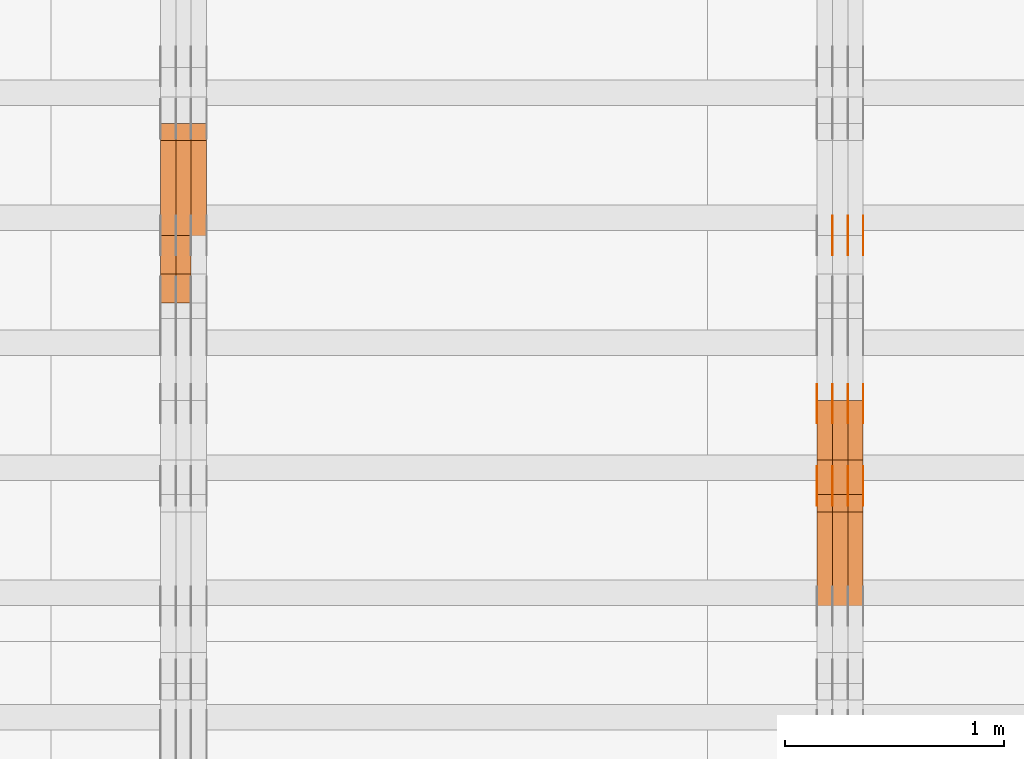
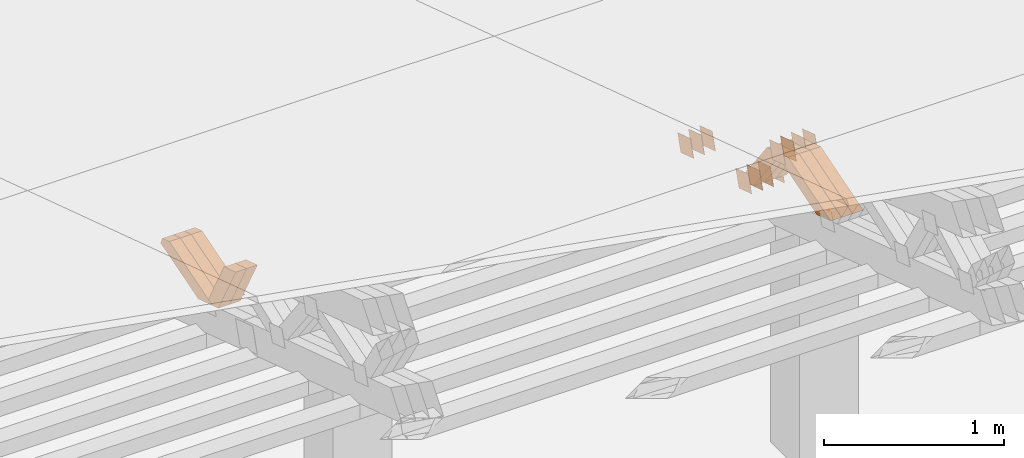
# One storey, part 199 of 385: 28 proxies.
"""IFC2X3 building model written with IfcOpenShell, lengths in millimetres."""

from ifc_helpers import new_model, entity, si_unit, converted_unit, derived_unit, direction, frame, origin, place, context, subcontext, project, spatial, polyline, outline, extrude, source, transform, mapped, material, type_object, type_shapes, element, save


model = new_model("IFC2X3")

# Units and contexts
model_context = context("Model", 3, precision=0.01, world=origin(), true_north=direction((6.12303176911189e-17, 1.0)))
body_context = subcontext(model_context, "Body", "Model", "MODEL_VIEW")
ifc_project = project(units=[si_unit("LENGTHUNIT", "METRE", prefix="MILLI"), si_unit("AREAUNIT", "SQUARE_METRE"), si_unit("VOLUMEUNIT", "CUBIC_METRE"), converted_unit("PLANEANGLEUNIT", "DEGREE", entity("IfcRatioMeasure", 0.0174532925199433), si_unit("PLANEANGLEUNIT", "RADIAN"), dimensions=[0, 0, 0, 0, 0, 0, 0]), si_unit("MASSUNIT", "GRAM", prefix="KILO"), derived_unit("MASSDENSITYUNIT", [(si_unit("MASSUNIT", "GRAM", prefix="KILO"), 1), (si_unit("LENGTHUNIT", "METRE"), -3)]), si_unit("TIMEUNIT", "SECOND"), si_unit("FREQUENCYUNIT", "HERTZ"), si_unit("THERMODYNAMICTEMPERATUREUNIT", "DEGREE_CELSIUS"), derived_unit("THERMALTRANSMITTANCEUNIT", [(si_unit("MASSUNIT", "GRAM", prefix="KILO"), 1), (si_unit("THERMODYNAMICTEMPERATUREUNIT", "KELVIN"), -1), (si_unit("TIMEUNIT", "SECOND"), -3)]), derived_unit("VOLUMETRICFLOWRATEUNIT", [(si_unit("LENGTHUNIT", "METRE"), 3), (si_unit("TIMEUNIT", "SECOND"), -1)]), si_unit("ELECTRICCURRENTUNIT", "AMPERE"), si_unit("ELECTRICVOLTAGEUNIT", "VOLT"), si_unit("POWERUNIT", "WATT"), si_unit("FORCEUNIT", "NEWTON", prefix="KILO"), si_unit("ILLUMINANCEUNIT", "LUX"), si_unit("LUMINOUSFLUXUNIT", "LUMEN"), si_unit("LUMINOUSINTENSITYUNIT", "CANDELA"), derived_unit("USERDEFINED", [(si_unit("MASSUNIT", "GRAM", prefix="KILO"), -1), (si_unit("LENGTHUNIT", "METRE"), -2), (si_unit("TIMEUNIT", "SECOND"), 3), (si_unit("LUMINOUSFLUXUNIT", "LUMEN"), 1)]), derived_unit("LINEARVELOCITYUNIT", [(si_unit("LENGTHUNIT", "METRE"), 1), (si_unit("TIMEUNIT", "SECOND"), -1)]), si_unit("PRESSUREUNIT", "PASCAL"), derived_unit("USERDEFINED", [(si_unit("LENGTHUNIT", "METRE"), -2), (si_unit("MASSUNIT", "GRAM", prefix="KILO"), 1), (si_unit("TIMEUNIT", "SECOND"), -2)])], contexts=[model_context])

# Site, building, storey
site_placement = place(None, origin())
site = spatial("IfcSite", under=ifc_project, at=site_placement, CompositionType="ELEMENT")
building_placement = place(site_placement, origin())
building = spatial("IfcBuilding", under=site, at=building_placement, CompositionType="ELEMENT")
storey_placement = place(building_placement, origin())
storey = spatial("IfcBuildingStorey", under=building, at=storey_placement, Name="Default", CompositionType="ELEMENT", Elevation=0.0)

# Proxies
ifc_material_1 = material(Name="IfcSurfaceStyle #206404")
building_element_proxy_type_1 = type_object("IfcBuildingElementProxyType", PredefinedType="NOTDEFINED", material=ifc_material_1)
shared_shape_1 = source(origin(), body_context, "Body", "SweptSolid", [
    extrude(outline(polyline([(-74.9998794200123, -59.999984515643), (74.9998565677174, -59.999984515643), (74.9998794200123, 59.999984515643), (-74.9998565677174, 59.999984515643), (-74.9998794200123, -59.999984515643)])), frame((75.0000769557496, 60.0000596852268, 0.0), z_axis=(0.0, 0.0, 1.0), x_axis=(-1.0, 0.0, 0.0)), (0.0, 0.0, 1.0), 1.3),
])
type_shapes(building_element_proxy_type_1, [shared_shape_1])
proxy_1_placement = place(building_placement, frame((15386.3, 22649.3668870864, 1282.62115477841), z_axis=(-1.0, 0.0, 0.0), x_axis=(0.0, -0.951056516295124, 0.309016994375039)))
element("IfcBuildingElementProxy", 1, at=proxy_1_placement, inside=storey, type_object=building_element_proxy_type_1, material=ifc_material_1, context=body_context, shape_type="MappedRepresentation", body=[
    mapped(shared_shape_1, transform((0.0, 0.0, 0.0), scale=1.0)),
])
ifc_material_2 = material(Name="IfcSurfaceStyle #206347")
building_element_proxy_type_2 = type_object("IfcBuildingElementProxyType", PredefinedType="NOTDEFINED", material=ifc_material_2)
shared_shape_2 = source(origin(), body_context, "Body", "SweptSolid", [
    extrude(outline(polyline([(-74.9998794200123, -59.999984515643), (74.9998565677174, -59.999984515643), (74.9998794200123, 59.999984515643), (-74.9998565677174, 59.999984515643), (-74.9998794200123, -59.999984515643)])), frame((75.0000769557496, 60.0000596852268, 0.0), z_axis=(0.0, 0.0, 1.0), x_axis=(-1.0, 0.0, 0.0)), (0.0, 0.0, 1.0), 1.3),
])
type_shapes(building_element_proxy_type_2, [shared_shape_2])
proxy_2_placement = place(building_placement, frame((15315.0, 22649.3668870864, 1282.62115477841), z_axis=(-1.0, 0.0, 0.0), x_axis=(0.0, -0.951056516295124, 0.309016994375039)))
element("IfcBuildingElementProxy", 2, at=proxy_2_placement, inside=storey, type_object=building_element_proxy_type_2, material=ifc_material_2, context=body_context, shape_type="MappedRepresentation", body=[
    mapped(shared_shape_2, transform((0.0, 0.0, 0.0), scale=1.0)),
])
ifc_material_3 = material(Name="IfcSurfaceStyle #206290")
building_element_proxy_type_3 = type_object("IfcBuildingElementProxyType", PredefinedType="NOTDEFINED", material=ifc_material_3)
shared_shape_3 = source(origin(), body_context, "Body", "SweptSolid", [
    extrude(outline(polyline([(-74.9998794200123, -59.999984515643), (74.9998565677174, -59.999984515643), (74.9998794200123, 59.999984515643), (-74.9998565677174, 59.999984515643), (-74.9998794200123, -59.999984515643)])), frame((75.0000769557496, 60.0000596852268, 0.0), z_axis=(0.0, 0.0, 1.0), x_axis=(-1.0, 0.0, 0.0)), (0.0, 0.0, 1.0), 1.3),
])
type_shapes(building_element_proxy_type_3, [shared_shape_3])
proxy_3_placement = place(building_placement, frame((15316.3, 22649.3668870864, 1282.62115477841), z_axis=(-1.0, 0.0, 0.0), x_axis=(0.0, -0.951056516295124, 0.309016994375039)))
element("IfcBuildingElementProxy", 3, at=proxy_3_placement, inside=storey, type_object=building_element_proxy_type_3, material=ifc_material_3, context=body_context, shape_type="MappedRepresentation", body=[
    mapped(shared_shape_3, transform((0.0, 0.0, 0.0), scale=1.0)),
])
ifc_material_4 = material(Name="IfcSurfaceStyle #206233")
building_element_proxy_type_4 = type_object("IfcBuildingElementProxyType", PredefinedType="NOTDEFINED", material=ifc_material_4)
shared_shape_4 = source(origin(), body_context, "Body", "SweptSolid", [
    extrude(outline(polyline([(-74.9998794200123, -59.999984515643), (74.9998565677174, -59.999984515643), (74.9998794200123, 59.999984515643), (-74.9998565677174, 59.999984515643), (-74.9998794200123, -59.999984515643)])), frame((75.0000769557496, 60.0000596852268, 0.0), z_axis=(0.0, 0.0, 1.0), x_axis=(-1.0, 0.0, 0.0)), (0.0, 0.0, 1.0), 1.29999999999999),
])
type_shapes(building_element_proxy_type_4, [shared_shape_4])
proxy_4_placement = place(building_placement, frame((15245.0, 22649.3668870864, 1282.62115477841), z_axis=(-1.0, 0.0, 0.0), x_axis=(0.0, -0.951056516295124, 0.309016994375039)))
element("IfcBuildingElementProxy", 4, at=proxy_4_placement, inside=storey, type_object=building_element_proxy_type_4, material=ifc_material_4, context=body_context, shape_type="MappedRepresentation", body=[
    mapped(shared_shape_4, transform((0.0, 0.0, 0.0), scale=1.0)),
])
ifc_material_5 = material(Name="IfcSurfaceStyle #206176")
building_element_proxy_type_5 = type_object("IfcBuildingElementProxyType", PredefinedType="NOTDEFINED", material=ifc_material_5)
shared_shape_5 = source(origin(), body_context, "Body", "SweptSolid", [
    extrude(outline(polyline([(-74.9998794200123, -59.999984515643), (74.9998565677174, -59.999984515643), (74.9998794200123, 59.999984515643), (-74.9998565677174, 59.999984515643), (-74.9998794200123, -59.999984515643)])), frame((75.0000769557496, 60.0000596852268, 0.0), z_axis=(0.0, 0.0, 1.0), x_axis=(-1.0, 0.0, 0.0)), (0.0, 0.0, 1.0), 1.29999999999999),
])
type_shapes(building_element_proxy_type_5, [shared_shape_5])
proxy_5_placement = place(building_placement, frame((15246.3, 22649.3668870864, 1282.62115477841), z_axis=(-1.0, 0.0, 0.0), x_axis=(0.0, -0.951056516295124, 0.309016994375039)))
element("IfcBuildingElementProxy", 5, at=proxy_5_placement, inside=storey, type_object=building_element_proxy_type_5, material=ifc_material_5, context=body_context, shape_type="MappedRepresentation", body=[
    mapped(shared_shape_5, transform((0.0, 0.0, 0.0), scale=1.0)),
])
ifc_material_6 = material(Name="IfcSurfaceStyle #203326")
building_element_proxy_type_6 = type_object("IfcBuildingElementProxyType", PredefinedType="NOTDEFINED", material=ifc_material_6)
shared_shape_6 = source(origin(), body_context, "Body", "SweptSolid", [
    extrude(outline(polyline([(-75.0001116115454, -60.0000599592451), (75.0000887592496, -60.0000599592451), (75.0001116115454, 60.0000599592451), (-75.0000887592496, 60.0000599592451), (-75.0001116115454, -60.0000599592451)])), frame((75.0001116115454, 60.0000599592451, 0.0), z_axis=(0.0, 0.0, 1.0), x_axis=(-1.0, 0.0, 0.0)), (0.0, 0.0, 1.0), 1.3),
])
type_shapes(building_element_proxy_type_6, [shared_shape_6])
proxy_6_placement = place(building_placement, frame((15386.3, 21881.0815195707, 1532.2522473242), z_axis=(-1.0, 0.0, 0.0), x_axis=(0.0, -0.951056516295124, 0.309016994375039)))
element("IfcBuildingElementProxy", 6, at=proxy_6_placement, inside=storey, type_object=building_element_proxy_type_6, material=ifc_material_6, context=body_context, shape_type="MappedRepresentation", body=[
    mapped(shared_shape_6, transform((0.0, 0.0, 0.0), scale=1.0)),
])
ifc_material_7 = material(Name="IfcSurfaceStyle #203269")
building_element_proxy_type_7 = type_object("IfcBuildingElementProxyType", PredefinedType="NOTDEFINED", material=ifc_material_7)
shared_shape_7 = source(origin(), body_context, "Body", "SweptSolid", [
    extrude(outline(polyline([(-75.0001116115454, -60.0000599592451), (75.0000887592496, -60.0000599592451), (75.0001116115454, 60.0000599592451), (-75.0000887592496, 60.0000599592451), (-75.0001116115454, -60.0000599592451)])), frame((75.0001116115454, 60.0000599592451, 0.0), z_axis=(0.0, 0.0, 1.0), x_axis=(-1.0, 0.0, 0.0)), (0.0, 0.0, 1.0), 1.3),
])
type_shapes(building_element_proxy_type_7, [shared_shape_7])
proxy_7_placement = place(building_placement, frame((15315.0, 21881.0815195707, 1532.2522473242), z_axis=(-1.0, 0.0, 0.0), x_axis=(0.0, -0.951056516295124, 0.309016994375039)))
element("IfcBuildingElementProxy", 7, at=proxy_7_placement, inside=storey, type_object=building_element_proxy_type_7, material=ifc_material_7, context=body_context, shape_type="MappedRepresentation", body=[
    mapped(shared_shape_7, transform((0.0, 0.0, 0.0), scale=1.0)),
])
ifc_material_8 = material(Name="IfcSurfaceStyle #203212")
building_element_proxy_type_8 = type_object("IfcBuildingElementProxyType", PredefinedType="NOTDEFINED", material=ifc_material_8)
shared_shape_8 = source(origin(), body_context, "Body", "SweptSolid", [
    extrude(outline(polyline([(-75.0001116115454, -60.0000599592451), (75.0000887592496, -60.0000599592451), (75.0001116115454, 60.0000599592451), (-75.0000887592496, 60.0000599592451), (-75.0001116115454, -60.0000599592451)])), frame((75.0001116115454, 60.0000599592451, 0.0), z_axis=(0.0, 0.0, 1.0), x_axis=(-1.0, 0.0, 0.0)), (0.0, 0.0, 1.0), 1.3),
])
type_shapes(building_element_proxy_type_8, [shared_shape_8])
proxy_8_placement = place(building_placement, frame((15316.3, 21881.0815195707, 1532.2522473242), z_axis=(-1.0, 0.0, 0.0), x_axis=(0.0, -0.951056516295124, 0.309016994375039)))
element("IfcBuildingElementProxy", 8, at=proxy_8_placement, inside=storey, type_object=building_element_proxy_type_8, material=ifc_material_8, context=body_context, shape_type="MappedRepresentation", body=[
    mapped(shared_shape_8, transform((0.0, 0.0, 0.0), scale=1.0)),
])
ifc_material_9 = material(Name="IfcSurfaceStyle #203155")
building_element_proxy_type_9 = type_object("IfcBuildingElementProxyType", PredefinedType="NOTDEFINED", material=ifc_material_9)
shared_shape_9 = source(origin(), body_context, "Body", "SweptSolid", [
    extrude(outline(polyline([(-75.0001116115454, -60.0000599592451), (75.0000887592496, -60.0000599592451), (75.0001116115454, 60.0000599592451), (-75.0000887592496, 60.0000599592451), (-75.0001116115454, -60.0000599592451)])), frame((75.0001116115454, 60.0000599592451, 0.0), z_axis=(0.0, 0.0, 1.0), x_axis=(-1.0, 0.0, 0.0)), (0.0, 0.0, 1.0), 1.29999999999999),
])
type_shapes(building_element_proxy_type_9, [shared_shape_9])
proxy_9_placement = place(building_placement, frame((15245.0, 21881.0815195707, 1532.2522473242), z_axis=(-1.0, 0.0, 0.0), x_axis=(0.0, -0.951056516295124, 0.309016994375039)))
element("IfcBuildingElementProxy", 9, at=proxy_9_placement, inside=storey, type_object=building_element_proxy_type_9, material=ifc_material_9, context=body_context, shape_type="MappedRepresentation", body=[
    mapped(shared_shape_9, transform((0.0, 0.0, 0.0), scale=1.0)),
])
ifc_material_10 = material(Name="IfcSurfaceStyle #203098")
building_element_proxy_type_10 = type_object("IfcBuildingElementProxyType", PredefinedType="NOTDEFINED", material=ifc_material_10)
shared_shape_10 = source(origin(), body_context, "Body", "SweptSolid", [
    extrude(outline(polyline([(-75.0001116115454, -60.0000599592451), (75.0000887592496, -60.0000599592451), (75.0001116115454, 60.0000599592451), (-75.0000887592496, 60.0000599592451), (-75.0001116115454, -60.0000599592451)])), frame((75.0001116115454, 60.0000599592451, 0.0), z_axis=(0.0, 0.0, 1.0), x_axis=(-1.0, 0.0, 0.0)), (0.0, 0.0, 1.0), 1.29999999999999),
])
type_shapes(building_element_proxy_type_10, [shared_shape_10])
proxy_10_placement = place(building_placement, frame((15246.3, 21881.0815195707, 1532.2522473242), z_axis=(-1.0, 0.0, 0.0), x_axis=(0.0, -0.951056516295124, 0.309016994375039)))
element("IfcBuildingElementProxy", 10, at=proxy_10_placement, inside=storey, type_object=building_element_proxy_type_10, material=ifc_material_10, context=body_context, shape_type="MappedRepresentation", body=[
    mapped(shared_shape_10, transform((0.0, 0.0, 0.0), scale=1.0)),
])
ifc_material_11 = material(Name="IfcSurfaceStyle #203041")
building_element_proxy_type_11 = type_object("IfcBuildingElementProxyType", PredefinedType="NOTDEFINED", material=ifc_material_11)
shared_shape_11 = source(origin(), body_context, "Body", "SweptSolid", [
    extrude(outline(polyline([(-75.0001116115454, -60.0000599592451), (75.0000887592496, -60.0000599592451), (75.0001116115454, 60.0000599592451), (-75.0000887592496, 60.0000599592451), (-75.0001116115454, -60.0000599592451)])), frame((75.0001116115454, 60.0000599592451, 0.0), z_axis=(0.0, 0.0, 1.0), x_axis=(-1.0, 0.0, 0.0)), (0.0, 0.0, 1.0), 1.29999999999999),
])
type_shapes(building_element_proxy_type_11, [shared_shape_11])
proxy_11_placement = place(building_placement, frame((15175.0, 21881.0815195707, 1532.2522473242), z_axis=(-1.0, 0.0, 0.0), x_axis=(0.0, -0.951056516295124, 0.309016994375039)))
element("IfcBuildingElementProxy", 11, at=proxy_11_placement, inside=storey, type_object=building_element_proxy_type_11, material=ifc_material_11, context=body_context, shape_type="MappedRepresentation", body=[
    mapped(shared_shape_11, transform((0.0, 0.0, 0.0), scale=1.0)),
])
ifc_material_12 = material(Name="IfcSurfaceStyle #197854")
building_element_proxy_type_12 = type_object("IfcBuildingElementProxyType", PredefinedType="NOTDEFINED", material=ifc_material_12)
shared_shape_12 = source(origin(), body_context, "Body", "SweptSolid", [
    extrude(outline(polyline([(-74.9998794200064, -59.9999845156358), (74.9998565677224, -59.9999845156358), (74.9998794200064, 59.9999845156358), (-74.9998565677224, 59.9999845156358), (-74.9998794200064, -59.9999845156358)])), frame((74.9999765995044, 60.0000596852337, 0.0), z_axis=(0.0, 0.0, 1.0), x_axis=(-1.0, 0.0, 0.0)), (0.0, 0.0, 1.0), 1.3),
])
type_shapes(building_element_proxy_type_12, [shared_shape_12])
proxy_12_placement = place(building_placement, frame((15386.3, 21505.9776314857, 1954.5332951652), z_axis=(-1.0, 0.0, 0.0), x_axis=(0.0, -0.951056516295154, 0.309016994374948)))
element("IfcBuildingElementProxy", 12, at=proxy_12_placement, inside=storey, type_object=building_element_proxy_type_12, material=ifc_material_12, context=body_context, shape_type="MappedRepresentation", body=[
    mapped(shared_shape_12, transform((0.0, 0.0, 0.0), scale=1.0)),
])
ifc_material_13 = material(Name="IfcSurfaceStyle #197797")
building_element_proxy_type_13 = type_object("IfcBuildingElementProxyType", PredefinedType="NOTDEFINED", material=ifc_material_13)
shared_shape_13 = source(origin(), body_context, "Body", "SweptSolid", [
    extrude(outline(polyline([(-74.9998794200064, -59.9999845156358), (74.9998565677224, -59.9999845156358), (74.9998794200064, 59.9999845156358), (-74.9998565677224, 59.9999845156358), (-74.9998794200064, -59.9999845156358)])), frame((74.9999765995044, 60.0000596852337, 0.0), z_axis=(0.0, 0.0, 1.0), x_axis=(-1.0, 0.0, 0.0)), (0.0, 0.0, 1.0), 1.3),
])
type_shapes(building_element_proxy_type_13, [shared_shape_13])
proxy_13_placement = place(building_placement, frame((15315.0, 21505.9776314857, 1954.5332951652), z_axis=(-1.0, 0.0, 0.0), x_axis=(0.0, -0.951056516295154, 0.309016994374948)))
element("IfcBuildingElementProxy", 13, at=proxy_13_placement, inside=storey, type_object=building_element_proxy_type_13, material=ifc_material_13, context=body_context, shape_type="MappedRepresentation", body=[
    mapped(shared_shape_13, transform((0.0, 0.0, 0.0), scale=1.0)),
])
ifc_material_14 = material(Name="IfcSurfaceStyle #197740")
building_element_proxy_type_14 = type_object("IfcBuildingElementProxyType", PredefinedType="NOTDEFINED", material=ifc_material_14)
shared_shape_14 = source(origin(), body_context, "Body", "SweptSolid", [
    extrude(outline(polyline([(-74.9998794200064, -59.9999845156358), (74.9998565677224, -59.9999845156358), (74.9998794200064, 59.9999845156358), (-74.9998565677224, 59.9999845156358), (-74.9998794200064, -59.9999845156358)])), frame((74.9999765995044, 60.0000596852337, 0.0), z_axis=(0.0, 0.0, 1.0), x_axis=(-1.0, 0.0, 0.0)), (0.0, 0.0, 1.0), 1.3),
])
type_shapes(building_element_proxy_type_14, [shared_shape_14])
proxy_14_placement = place(building_placement, frame((15316.3, 21505.9776314857, 1954.5332951652), z_axis=(-1.0, 0.0, 0.0), x_axis=(0.0, -0.951056516295154, 0.309016994374948)))
element("IfcBuildingElementProxy", 14, at=proxy_14_placement, inside=storey, type_object=building_element_proxy_type_14, material=ifc_material_14, context=body_context, shape_type="MappedRepresentation", body=[
    mapped(shared_shape_14, transform((0.0, 0.0, 0.0), scale=1.0)),
])
ifc_material_15 = material(Name="IfcSurfaceStyle #197683")
building_element_proxy_type_15 = type_object("IfcBuildingElementProxyType", PredefinedType="NOTDEFINED", material=ifc_material_15)
shared_shape_15 = source(origin(), body_context, "Body", "SweptSolid", [
    extrude(outline(polyline([(-74.9998794200064, -59.9999845156358), (74.9998565677224, -59.9999845156358), (74.9998794200064, 59.9999845156358), (-74.9998565677224, 59.9999845156358), (-74.9998794200064, -59.9999845156358)])), frame((74.9999765995044, 60.0000596852337, 0.0), z_axis=(0.0, 0.0, 1.0), x_axis=(-1.0, 0.0, 0.0)), (0.0, 0.0, 1.0), 1.29999999999999),
])
type_shapes(building_element_proxy_type_15, [shared_shape_15])
proxy_15_placement = place(building_placement, frame((15245.0, 21505.9776314857, 1954.5332951652), z_axis=(-1.0, 0.0, 0.0), x_axis=(0.0, -0.951056516295154, 0.309016994374948)))
element("IfcBuildingElementProxy", 15, at=proxy_15_placement, inside=storey, type_object=building_element_proxy_type_15, material=ifc_material_15, context=body_context, shape_type="MappedRepresentation", body=[
    mapped(shared_shape_15, transform((0.0, 0.0, 0.0), scale=1.0)),
])
ifc_material_16 = material(Name="IfcSurfaceStyle #197626")
building_element_proxy_type_16 = type_object("IfcBuildingElementProxyType", PredefinedType="NOTDEFINED", material=ifc_material_16)
shared_shape_16 = source(origin(), body_context, "Body", "SweptSolid", [
    extrude(outline(polyline([(-74.9998794200064, -59.9999845156358), (74.9998565677224, -59.9999845156358), (74.9998794200064, 59.9999845156358), (-74.9998565677224, 59.9999845156358), (-74.9998794200064, -59.9999845156358)])), frame((74.9999765995044, 60.0000596852337, 0.0), z_axis=(0.0, 0.0, 1.0), x_axis=(-1.0, 0.0, 0.0)), (0.0, 0.0, 1.0), 1.29999999999999),
])
type_shapes(building_element_proxy_type_16, [shared_shape_16])
proxy_16_placement = place(building_placement, frame((15246.3, 21505.9776314857, 1954.5332951652), z_axis=(-1.0, 0.0, 0.0), x_axis=(0.0, -0.951056516295154, 0.309016994374948)))
element("IfcBuildingElementProxy", 16, at=proxy_16_placement, inside=storey, type_object=building_element_proxy_type_16, material=ifc_material_16, context=body_context, shape_type="MappedRepresentation", body=[
    mapped(shared_shape_16, transform((0.0, 0.0, 0.0), scale=1.0)),
])
ifc_material_17 = material(Name="IfcSurfaceStyle #197569")
building_element_proxy_type_17 = type_object("IfcBuildingElementProxyType", PredefinedType="NOTDEFINED", material=ifc_material_17)
shared_shape_17 = source(origin(), body_context, "Body", "SweptSolid", [
    extrude(outline(polyline([(-74.9998794200064, -59.9999845156358), (74.9998565677224, -59.9999845156358), (74.9998794200064, 59.9999845156358), (-74.9998565677224, 59.9999845156358), (-74.9998794200064, -59.9999845156358)])), frame((74.9999765995044, 60.0000596852337, 0.0), z_axis=(0.0, 0.0, 1.0), x_axis=(-1.0, 0.0, 0.0)), (0.0, 0.0, 1.0), 1.29999999999999),
])
type_shapes(building_element_proxy_type_17, [shared_shape_17])
proxy_17_placement = place(building_placement, frame((15175.0, 21505.9776314857, 1954.5332951652), z_axis=(-1.0, 0.0, 0.0), x_axis=(0.0, -0.951056516295154, 0.309016994374948)))
element("IfcBuildingElementProxy", 17, at=proxy_17_placement, inside=storey, type_object=building_element_proxy_type_17, material=ifc_material_17, context=body_context, shape_type="MappedRepresentation", body=[
    mapped(shared_shape_17, transform((0.0, 0.0, 0.0), scale=1.0)),
])
ifc_material_18 = material(Name="IfcSurfaceStyle #185614")
building_element_proxy_type_18 = type_object("IfcBuildingElementProxyType", Name="T1-W20 185612", PredefinedType="NOTDEFINED", material=ifc_material_18)
shared_shape_18 = source(origin(), body_context, "Body", "SweptSolid", [
    extrude(outline(polyline([(-355.264945969921, -47.5000317999193), (141.064821099313, -47.5000317999193), (208.541978467889, 8.19311626391928e-05), (225.96877763549, 47.499990834338), (-220.31063123277, 47.4999908343379), (-355.264945969921, -47.5000317999193)])), frame((225.968921063481, 47.5000683592689, 0.0), z_axis=(0.0, 0.0, 1.0), x_axis=(-1.0, 0.0, 0.0)), (0.0, 0.0, 1.0), 70.0),
])
type_shapes(building_element_proxy_type_18, [shared_shape_18])
proxy_18_placement = place(building_placement, frame((15385.0, 21443.7472302196, 2007.54830804072), z_axis=(-1.0, 0.0, 0.0), x_axis=(0.0, -0.95556995517236, -0.29476441571515)))
element("IfcBuildingElementProxy", 18, at=proxy_18_placement, inside=storey, type_object=building_element_proxy_type_18, material=ifc_material_18, Name="T1-W20", context=body_context, shape_type="MappedRepresentation", body=[
    mapped(shared_shape_18, transform((0.0, 0.0, 0.0), scale=1.0)),
])
ifc_material_19 = material(Name="IfcSurfaceStyle #185548")
building_element_proxy_type_19 = type_object("IfcBuildingElementProxyType", Name="T1-W20 185546", PredefinedType="NOTDEFINED", material=ifc_material_19)
shared_shape_19 = source(origin(), body_context, "Body", "SweptSolid", [
    extrude(outline(polyline([(-355.264945969921, -47.5000317999193), (141.064821099313, -47.5000317999193), (208.541978467889, 8.19311626391928e-05), (225.96877763549, 47.499990834338), (-220.31063123277, 47.4999908343379), (-355.264945969921, -47.5000317999193)])), frame((225.968921063481, 47.5000683592689, 0.0), z_axis=(0.0, 0.0, 1.0), x_axis=(-1.0, 0.0, 0.0)), (0.0, 0.0, 1.0), 70.0),
])
type_shapes(building_element_proxy_type_19, [shared_shape_19])
proxy_19_placement = place(building_placement, frame((15315.0, 21443.7472302196, 2007.54830804072), z_axis=(-1.0, 0.0, 0.0), x_axis=(0.0, -0.95556995517236, -0.29476441571515)))
element("IfcBuildingElementProxy", 19, at=proxy_19_placement, inside=storey, type_object=building_element_proxy_type_19, material=ifc_material_19, Name="T1-W20", context=body_context, shape_type="MappedRepresentation", body=[
    mapped(shared_shape_19, transform((0.0, 0.0, 0.0), scale=1.0)),
])
ifc_material_20 = material(Name="IfcSurfaceStyle #185482")
building_element_proxy_type_20 = type_object("IfcBuildingElementProxyType", Name="T1-W20 185480", PredefinedType="NOTDEFINED", material=ifc_material_20)
shared_shape_20 = source(origin(), body_context, "Body", "SweptSolid", [
    extrude(outline(polyline([(-355.264945969921, -47.5000317999193), (141.064821099313, -47.5000317999193), (208.541978467889, 8.19311626391928e-05), (225.96877763549, 47.499990834338), (-220.31063123277, 47.4999908343379), (-355.264945969921, -47.5000317999193)])), frame((225.968921063481, 47.5000683592689, 0.0), z_axis=(0.0, 0.0, 1.0), x_axis=(-1.0, 0.0, 0.0)), (0.0, 0.0, 1.0), 70.0),
])
type_shapes(building_element_proxy_type_20, [shared_shape_20])
proxy_20_placement = place(building_placement, frame((15245.0, 21443.7472302196, 2007.54830804072), z_axis=(-1.0, 0.0, 0.0), x_axis=(0.0, -0.95556995517236, -0.29476441571515)))
element("IfcBuildingElementProxy", 20, at=proxy_20_placement, inside=storey, type_object=building_element_proxy_type_20, material=ifc_material_20, Name="T1-W20", context=body_context, shape_type="MappedRepresentation", body=[
    mapped(shared_shape_20, transform((0.0, 0.0, 0.0), scale=1.0)),
])
ifc_material_21 = material(Name="IfcSurfaceStyle #185218")
building_element_proxy_type_21 = type_object("IfcBuildingElementProxyType", Name="T1-W18 185216", PredefinedType="NOTDEFINED", material=ifc_material_21)
shared_shape_21 = source(origin(), body_context, "Body", "SweptSolid", [
    extrude(outline(polyline([(-221.504996322134, -47.4999929258616), (225.406467948779, -47.4999929258616), (211.663832468686, -0.000107703153482008), (143.08905281687, 47.5000467774384), (-358.6543569122, 47.5000467774384), (-221.504996322134, -47.4999929258616)])), frame((225.406576158364, 47.5000467774384, 0.0), z_axis=(0.0, 0.0, 1.0), x_axis=(-1.0, 0.0, 0.0)), (0.0, 0.0, 1.0), 70.0),
])
type_shapes(building_element_proxy_type_21, [shared_shape_21])
proxy_21_placement = place(building_placement, frame((15385.0, 21766.9513837803, 1583.13813361817), z_axis=(-1.0, 0.0, 0.0), x_axis=(0.0, -0.605858491298265, 0.795572428206126)))
element("IfcBuildingElementProxy", 21, at=proxy_21_placement, inside=storey, type_object=building_element_proxy_type_21, material=ifc_material_21, Name="T1-W18", context=body_context, shape_type="MappedRepresentation", body=[
    mapped(shared_shape_21, transform((0.0, 0.0, 0.0), scale=1.0)),
])
ifc_material_22 = material(Name="IfcSurfaceStyle #185152")
building_element_proxy_type_22 = type_object("IfcBuildingElementProxyType", Name="T1-W18 185150", PredefinedType="NOTDEFINED", material=ifc_material_22)
shared_shape_22 = source(origin(), body_context, "Body", "SweptSolid", [
    extrude(outline(polyline([(-221.504996322134, -47.4999929258616), (225.406467948779, -47.4999929258616), (211.663832468686, -0.000107703153482008), (143.08905281687, 47.5000467774384), (-358.6543569122, 47.5000467774384), (-221.504996322134, -47.4999929258616)])), frame((225.406576158364, 47.5000467774384, 0.0), z_axis=(0.0, 0.0, 1.0), x_axis=(-1.0, 0.0, 0.0)), (0.0, 0.0, 1.0), 70.0),
])
type_shapes(building_element_proxy_type_22, [shared_shape_22])
proxy_22_placement = place(building_placement, frame((15315.0, 21766.9513837803, 1583.13813361817), z_axis=(-1.0, 0.0, 0.0), x_axis=(0.0, -0.605858491298265, 0.795572428206126)))
element("IfcBuildingElementProxy", 22, at=proxy_22_placement, inside=storey, type_object=building_element_proxy_type_22, material=ifc_material_22, Name="T1-W18", context=body_context, shape_type="MappedRepresentation", body=[
    mapped(shared_shape_22, transform((0.0, 0.0, 0.0), scale=1.0)),
])
ifc_material_23 = material(Name="IfcSurfaceStyle #185086")
building_element_proxy_type_23 = type_object("IfcBuildingElementProxyType", Name="T1-W18 185084", PredefinedType="NOTDEFINED", material=ifc_material_23)
shared_shape_23 = source(origin(), body_context, "Body", "SweptSolid", [
    extrude(outline(polyline([(-221.504996322134, -47.4999929258616), (225.406467948779, -47.4999929258616), (211.663832468686, -0.000107703153482008), (143.08905281687, 47.5000467774384), (-358.6543569122, 47.5000467774384), (-221.504996322134, -47.4999929258616)])), frame((225.406576158364, 47.5000467774384, 0.0), z_axis=(0.0, 0.0, 1.0), x_axis=(-1.0, 0.0, 0.0)), (0.0, 0.0, 1.0), 70.0),
])
type_shapes(building_element_proxy_type_23, [shared_shape_23])
proxy_23_placement = place(building_placement, frame((15245.0, 21766.9513837803, 1583.13813361817), z_axis=(-1.0, 0.0, 0.0), x_axis=(0.0, -0.605858491298265, 0.795572428206126)))
element("IfcBuildingElementProxy", 23, at=proxy_23_placement, inside=storey, type_object=building_element_proxy_type_23, material=ifc_material_23, Name="T1-W18", context=body_context, shape_type="MappedRepresentation", body=[
    mapped(shared_shape_23, transform((0.0, 0.0, 0.0), scale=1.0)),
])
ifc_material_24 = material(Name="IfcSurfaceStyle #149928")
building_element_proxy_type_24 = type_object("IfcBuildingElementProxyType", Name="T1-W41 149926", PredefinedType="NOTDEFINED", material=ifc_material_24)
shared_shape_24 = source(origin(), body_context, "Body", "SweptSolid", [
    extrude(outline(polyline([(-190.064783497519, -47.5001011048749), (182.590736871656, -47.5001011048749), (172.978793750747, 0.000111395300689243), (123.505951450908, 47.5000454072246), (-289.010698575792, 47.5000454072246), (-190.064783497519, -47.5001011048749)])), frame((182.590736871656, 47.5001973817447, 0.0), z_axis=(0.0, 0.0, 1.0), x_axis=(-1.0, 0.0, 0.0)), (0.0, 0.0, 1.0), 70.0),
])
type_shapes(building_element_proxy_type_24, [shared_shape_24])
proxy_24_placement = place(building_placement, frame((12315.0, 22512.5506969063, 1347.13648051689), z_axis=(-1.0, 0.0, 0.0), x_axis=(0.0, -0.472020158706979, 0.881587755004706)))
element("IfcBuildingElementProxy", 24, at=proxy_24_placement, inside=storey, type_object=building_element_proxy_type_24, material=ifc_material_24, Name="T1-W41", context=body_context, shape_type="MappedRepresentation", body=[
    mapped(shared_shape_24, transform((0.0, 0.0, 0.0), scale=1.0)),
])
ifc_material_25 = material(Name="IfcSurfaceStyle #149862")
building_element_proxy_type_25 = type_object("IfcBuildingElementProxyType", Name="T1-W41 149860", PredefinedType="NOTDEFINED", material=ifc_material_25)
shared_shape_25 = source(origin(), body_context, "Body", "SweptSolid", [
    extrude(outline(polyline([(-190.064783497519, -47.5001011048749), (182.590736871656, -47.5001011048749), (172.978793750747, 0.000111395300689243), (123.505951450908, 47.5000454072246), (-289.010698575792, 47.5000454072246), (-190.064783497519, -47.5001011048749)])), frame((182.590736871656, 47.5001973817447, 0.0), z_axis=(0.0, 0.0, 1.0), x_axis=(-1.0, 0.0, 0.0)), (0.0, 0.0, 1.0), 70.0),
])
type_shapes(building_element_proxy_type_25, [shared_shape_25])
proxy_25_placement = place(building_placement, frame((12245.0, 22512.5506969063, 1347.13648051689), z_axis=(-1.0, 0.0, 0.0), x_axis=(0.0, -0.472020158706979, 0.881587755004706)))
element("IfcBuildingElementProxy", 25, at=proxy_25_placement, inside=storey, type_object=building_element_proxy_type_25, material=ifc_material_25, Name="T1-W41", context=body_context, shape_type="MappedRepresentation", body=[
    mapped(shared_shape_25, transform((0.0, 0.0, 0.0), scale=1.0)),
])
ifc_material_26 = material(Name="IfcSurfaceStyle #149598")
building_element_proxy_type_26 = type_object("IfcBuildingElementProxyType", Name="T1-W23 149596", PredefinedType="NOTDEFINED", material=ifc_material_26)
shared_shape_26 = source(origin(), body_context, "Body", "SweptSolid", [
    extrude(outline(polyline([(-356.808656505462, -47.5000180192671), (144.726334557508, -47.5000180192671), (213.258834104997, -2.90494310381195e-05), (218.567145253444, 47.5000325439826), (-219.743657410487, 47.5000325439827), (-356.808656505462, -47.5000180192671)])), frame((218.567145253444, 47.5000325439826, 0.0), z_axis=(0.0, 0.0, 1.0), x_axis=(-1.0, 0.0, 0.0)), (0.0, 0.0, 1.0), 70.0),
])
type_shapes(building_element_proxy_type_26, [shared_shape_26])
proxy_26_placement = place(building_placement, frame((12385.0, 23128.2626953125, 1452.63940429688), z_axis=(-1.0, 0.0, 0.0), x_axis=(0.0, -0.957692700226705, -0.287792793399143)))
element("IfcBuildingElementProxy", 26, at=proxy_26_placement, inside=storey, type_object=building_element_proxy_type_26, material=ifc_material_26, Name="T1-W23", context=body_context, shape_type="MappedRepresentation", body=[
    mapped(shared_shape_26, transform((0.0, 0.0, 0.0), scale=1.0)),
])
ifc_material_27 = material(Name="IfcSurfaceStyle #149532")
building_element_proxy_type_27 = type_object("IfcBuildingElementProxyType", Name="T1-W23 149530", PredefinedType="NOTDEFINED", material=ifc_material_27)
shared_shape_27 = source(origin(), body_context, "Body", "SweptSolid", [
    extrude(outline(polyline([(-356.808656505462, -47.5000180192671), (144.726334557508, -47.5000180192671), (213.258834104997, -2.90494310381195e-05), (218.567145253444, 47.5000325439826), (-219.743657410487, 47.5000325439827), (-356.808656505462, -47.5000180192671)])), frame((218.567145253444, 47.5000325439826, 0.0), z_axis=(0.0, 0.0, 1.0), x_axis=(-1.0, 0.0, 0.0)), (0.0, 0.0, 1.0), 70.0),
])
type_shapes(building_element_proxy_type_27, [shared_shape_27])
proxy_27_placement = place(building_placement, frame((12315.0, 23128.2626953125, 1452.63940429688), z_axis=(-1.0, 0.0, 0.0), x_axis=(0.0, -0.957692700226705, -0.287792793399143)))
element("IfcBuildingElementProxy", 27, at=proxy_27_placement, inside=storey, type_object=building_element_proxy_type_27, material=ifc_material_27, Name="T1-W23", context=body_context, shape_type="MappedRepresentation", body=[
    mapped(shared_shape_27, transform((0.0, 0.0, 0.0), scale=1.0)),
])
ifc_material_28 = material(Name="IfcSurfaceStyle #149466")
building_element_proxy_type_28 = type_object("IfcBuildingElementProxyType", Name="T1-W23 149464", PredefinedType="NOTDEFINED", material=ifc_material_28)
shared_shape_28 = source(origin(), body_context, "Body", "SweptSolid", [
    extrude(outline(polyline([(-356.808656505462, -47.5000180192671), (144.726334557508, -47.5000180192671), (213.258834104997, -2.90494310381195e-05), (218.567145253444, 47.5000325439826), (-219.743657410487, 47.5000325439827), (-356.808656505462, -47.5000180192671)])), frame((218.567145253444, 47.5000325439826, 0.0), z_axis=(0.0, 0.0, 1.0), x_axis=(-1.0, 0.0, 0.0)), (0.0, 0.0, 1.0), 70.0),
])
type_shapes(building_element_proxy_type_28, [shared_shape_28])
proxy_28_placement = place(building_placement, frame((12245.0, 23128.2626953125, 1452.63940429688), z_axis=(-1.0, 0.0, 0.0), x_axis=(0.0, -0.957692700226705, -0.287792793399143)))
element("IfcBuildingElementProxy", 28, at=proxy_28_placement, inside=storey, type_object=building_element_proxy_type_28, material=ifc_material_28, Name="T1-W23", context=body_context, shape_type="MappedRepresentation", body=[
    mapped(shared_shape_28, transform((0.0, 0.0, 0.0), scale=1.0)),
])

save(model, "model.ifc")
